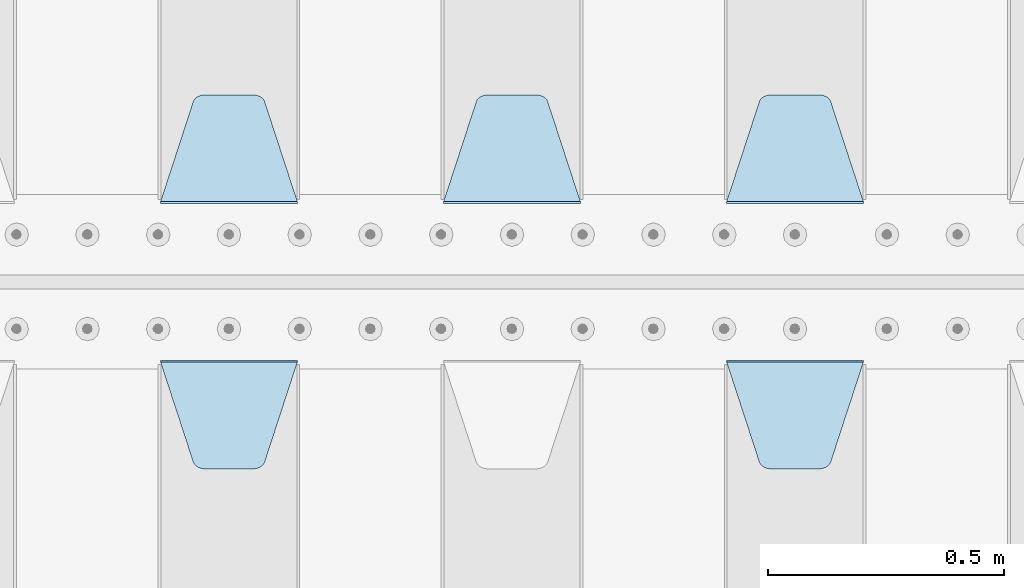
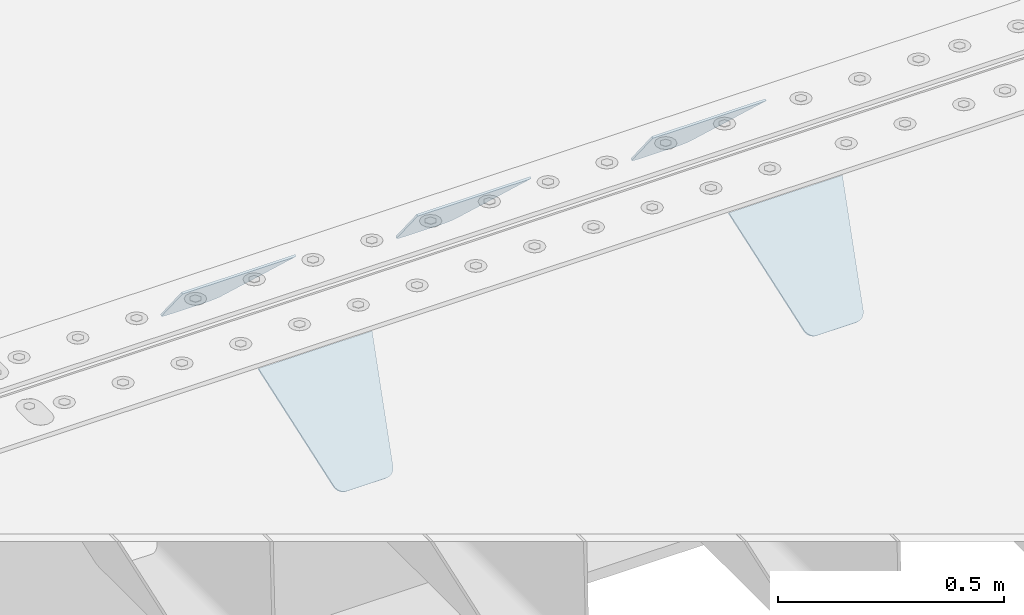
# One storey, part 211 of 247: 5 plates.
"""IFC2X3 building model written with IfcOpenShell, lengths in millimetres."""

from ifc_helpers import new_model, si_unit, frame, origin_with_axes, place, context, subcontext, project, spatial, faceted_brep, material, type_object, element, save


model = new_model("IFC2X3")

# Units and contexts
model_context = context("Model", 3, precision=1e-05, world=origin_with_axes())
body_context = subcontext(model_context, "Body", "Model", "MODEL_VIEW")
ifc_project = project(units=[si_unit("LENGTHUNIT", "METRE", prefix="MILLI"), si_unit("AREAUNIT", "SQUARE_METRE"), si_unit("VOLUMEUNIT", "CUBIC_METRE"), si_unit("MASSUNIT", "GRAM", prefix="KILO"), si_unit("TIMEUNIT", "SECOND"), si_unit("PLANEANGLEUNIT", "RADIAN"), si_unit("SOLIDANGLEUNIT", "STERADIAN"), si_unit("THERMODYNAMICTEMPERATUREUNIT", "DEGREE_CELSIUS"), si_unit("LUMINOUSINTENSITYUNIT", "LUMEN")], contexts=[model_context])

# Site, building, storey
site_placement = place(None, origin_with_axes())
site = spatial("IfcSite", under=ifc_project, at=site_placement, CompositionType="ELEMENT")
building_placement = place(site_placement, origin_with_axes())
building = spatial("IfcBuilding", under=site, at=building_placement, Name="Standard", CompositionType="ELEMENT")
storey_placement = place(building_placement, origin_with_axes())
storey = spatial("IfcBuildingStorey", under=building, at=storey_placement, Name="Undefined", CompositionType="ELEMENT", Elevation=0.0)

# Plates
ifc_material = material(Name="STEEL/S355N")
plate_type = type_object("IfcPlateType", PredefinedType="NOTDEFINED")
plate_1_placement = place(storey_placement, frame((14645.0, 6168.23223304704, -1.76776695296758), z_axis=(0.0, 0.707106781186548, -0.707106781186547), x_axis=(-1.0, 0.0, 0.0)))
element("IfcPlate", 1, at=plate_1_placement, inside=storey, type_object=plate_type, material=ifc_material, context=body_context, shape_type="Brep", body=[
    faceted_brep([(0.0, -2.49999999999909, 0.0), (69.345504679477, -2.5, 300.17173142483), (69.345504679477, 2.50000000000091, 300.171731424831), (0.0, 2.5, -9.09494701772928e-13), (70.9274061199576, -2.5, 304.897442415399), (70.9274061199576, 2.50000000000091, 304.8974424154), (73.3818627772307, -2.49999999999909, 309.234538108527), (73.3818627772307, 2.5, 309.234538108526), (76.6187032999551, -2.5, 313.023683126102), (76.6187032999551, 2.50000000000091, 313.023683126102), (80.5190132704993, -2.49999999999909, 316.125672595371), (80.5190132704993, 2.50000000000091, 316.125672595372), (84.9395038596849, -2.49999999999909, 318.426546230476), (84.9395038596849, 2.5, 318.426546230475), (89.7177759439219, -2.5, 319.841774983274), (89.7177759439219, 2.50000000000091, 319.841774983275), (94.678286292652, -2.5, 320.319366455077), (94.678286292652, 2.50000000000091, 320.319366455077), (195.321713707348, -2.5, 320.319366455077), (195.321713707348, 2.50000000000091, 320.319366455077), (200.282224056078, -2.5, 319.841774983274), (200.282224056078, 2.50000000000091, 319.841774983275), (205.060496140315, -2.5, 318.426546230475), (205.060496140315, 2.5, 318.426546230474), (209.480986729501, -2.49999999999818, 316.12567259537), (209.480986729501, 2.50000000000091, 316.12567259537), (213.381296700045, -2.5, 313.023683126101), (213.381296700045, 2.50000000000091, 313.023683126101), (216.618137222769, -2.5, 309.234538108525), (216.618137222769, 2.5, 309.234538108525), (219.072593880042, -2.49999999999909, 304.897442415398), (219.072593880042, 2.5, 304.897442415398), (220.654495320523, -2.5, 300.17173142483), (220.654495320523, 2.50000000000091, 300.171731424831), (290.0, -2.49999999999909, 0.0), (290.0, 2.5, -9.09494701772928e-13)], [[[0, 1, 2, 3]], [[1, 4, 5, 2]], [[4, 6, 7, 5]], [[6, 8, 9, 7]], [[8, 10, 11, 9]], [[10, 12, 13, 11]], [[12, 14, 15, 13]], [[14, 16, 17, 15]], [[16, 18, 19, 17]], [[18, 20, 21, 19]], [[20, 22, 23, 21]], [[22, 24, 25, 23]], [[24, 26, 27, 25]], [[26, 28, 29, 27]], [[28, 30, 31, 29]], [[30, 32, 33, 31]], [[32, 34, 35, 33]], [[34, 0, 3, 35]], [[5, 7, 9, 11, 13, 15, 17, 19, 21, 23, 25, 27, 29, 31, 33, 35, 3, 2]], [[34, 32, 30, 28, 26, 24, 22, 20, 18, 16, 14, 12, 10, 8, 6, 4, 1, 0]]]),
])
plate_2_placement = place(storey_placement, frame((14355.0, 5831.76776695594, -1.767766952965), z_axis=(0.0, -0.707106781186548, -0.707106781186547), x_axis=(1.0, 0.0, 0.0)))
element("IfcPlate", 2, at=plate_2_placement, inside=storey, type_object=plate_type, material=ifc_material, context=body_context, shape_type="Brep", body=[
    faceted_brep([(0.0, -2.49999999999909, 0.0), (69.345504679477, -2.5, 300.17173142483), (69.345504679477, 2.50000000000091, 300.171731424831), (0.0, 2.5, -9.09494701772928e-13), (70.9274061199576, -2.5, 304.897442415399), (70.9274061199576, 2.50000000000091, 304.8974424154), (73.3818627772307, -2.49999999999909, 309.234538108527), (73.3818627772307, 2.5, 309.234538108526), (76.6187032999551, -2.5, 313.023683126102), (76.6187032999551, 2.50000000000091, 313.023683126102), (80.5190132704993, -2.49999999999909, 316.125672595371), (80.5190132704993, 2.50000000000091, 316.125672595372), (84.9395038596849, -2.49999999999909, 318.426546230476), (84.9395038596849, 2.5, 318.426546230475), (89.7177759439219, -2.5, 319.841774983274), (89.7177759439219, 2.50000000000091, 319.841774983275), (94.678286292652, -2.5, 320.319366455077), (94.678286292652, 2.50000000000091, 320.319366455077), (195.321713707348, -2.5, 320.319366455077), (195.321713707348, 2.50000000000091, 320.319366455077), (200.282224056078, -2.5, 319.841774983274), (200.282224056078, 2.50000000000091, 319.841774983275), (205.060496140315, -2.5, 318.426546230475), (205.060496140315, 2.5, 318.426546230474), (209.480986729501, -2.49999999999818, 316.12567259537), (209.480986729501, 2.50000000000091, 316.12567259537), (213.381296700045, -2.5, 313.023683126101), (213.381296700045, 2.50000000000091, 313.023683126101), (216.618137222769, -2.5, 309.234538108525), (216.618137222769, 2.5, 309.234538108525), (219.072593880042, -2.49999999999909, 304.897442415398), (219.072593880042, 2.5, 304.897442415398), (220.654495320523, -2.5, 300.17173142483), (220.654495320523, 2.50000000000091, 300.171731424831), (290.0, -2.49999999999909, 0.0), (290.0, 2.5, -9.09494701772928e-13)], [[[0, 1, 2, 3]], [[1, 4, 5, 2]], [[4, 6, 7, 5]], [[6, 8, 9, 7]], [[8, 10, 11, 9]], [[10, 12, 13, 11]], [[12, 14, 15, 13]], [[14, 16, 17, 15]], [[16, 18, 19, 17]], [[18, 20, 21, 19]], [[20, 22, 23, 21]], [[22, 24, 25, 23]], [[24, 26, 27, 25]], [[26, 28, 29, 27]], [[28, 30, 31, 29]], [[30, 32, 33, 31]], [[32, 34, 35, 33]], [[34, 0, 3, 35]], [[5, 7, 9, 11, 13, 15, 17, 19, 21, 23, 25, 27, 29, 31, 33, 35, 3, 2]], [[34, 32, 30, 28, 26, 24, 22, 20, 18, 16, 14, 12, 10, 8, 6, 4, 1, 0]]]),
])
plate_3_placement = place(storey_placement, frame((13155.0, 5831.76776695594, -1.767766952965), z_axis=(0.0, -0.707106781186548, -0.707106781186547), x_axis=(1.0, 0.0, 0.0)))
element("IfcPlate", 3, at=plate_3_placement, inside=storey, type_object=plate_type, material=ifc_material, context=body_context, shape_type="Brep", body=[
    faceted_brep([(0.0, -2.49999999999909, 0.0), (69.345504679477, -2.5, 300.17173142483), (69.345504679477, 2.50000000000091, 300.171731424831), (0.0, 2.5, -9.09494701772928e-13), (70.9274061199576, -2.5, 304.897442415399), (70.9274061199576, 2.50000000000091, 304.8974424154), (73.3818627772307, -2.49999999999909, 309.234538108527), (73.3818627772307, 2.5, 309.234538108526), (76.6187032999551, -2.5, 313.023683126102), (76.6187032999551, 2.50000000000091, 313.023683126102), (80.5190132704993, -2.49999999999909, 316.125672595371), (80.5190132704993, 2.50000000000091, 316.125672595372), (84.9395038596849, -2.49999999999909, 318.426546230476), (84.9395038596849, 2.5, 318.426546230475), (89.7177759439219, -2.5, 319.841774983274), (89.7177759439219, 2.50000000000091, 319.841774983275), (94.678286292652, -2.5, 320.319366455077), (94.678286292652, 2.50000000000091, 320.319366455077), (195.321713707348, -2.5, 320.319366455077), (195.321713707348, 2.50000000000091, 320.319366455077), (200.282224056078, -2.5, 319.841774983274), (200.282224056078, 2.50000000000091, 319.841774983275), (205.060496140315, -2.5, 318.426546230475), (205.060496140315, 2.5, 318.426546230474), (209.480986729501, -2.49999999999818, 316.12567259537), (209.480986729501, 2.50000000000091, 316.12567259537), (213.381296700045, -2.5, 313.023683126101), (213.381296700045, 2.50000000000091, 313.023683126101), (216.618137222769, -2.5, 309.234538108525), (216.618137222769, 2.5, 309.234538108525), (219.072593880042, -2.49999999999909, 304.897442415398), (219.072593880042, 2.5, 304.897442415398), (220.654495320523, -2.5, 300.17173142483), (220.654495320523, 2.50000000000091, 300.171731424831), (290.0, -2.49999999999909, 0.0), (290.0, 2.5, -9.09494701772928e-13)], [[[0, 1, 2, 3]], [[1, 4, 5, 2]], [[4, 6, 7, 5]], [[6, 8, 9, 7]], [[8, 10, 11, 9]], [[10, 12, 13, 11]], [[12, 14, 15, 13]], [[14, 16, 17, 15]], [[16, 18, 19, 17]], [[18, 20, 21, 19]], [[20, 22, 23, 21]], [[22, 24, 25, 23]], [[24, 26, 27, 25]], [[26, 28, 29, 27]], [[28, 30, 31, 29]], [[30, 32, 33, 31]], [[32, 34, 35, 33]], [[34, 0, 3, 35]], [[5, 7, 9, 11, 13, 15, 17, 19, 21, 23, 25, 27, 29, 31, 33, 35, 3, 2]], [[34, 32, 30, 28, 26, 24, 22, 20, 18, 16, 14, 12, 10, 8, 6, 4, 1, 0]]]),
])
plate_4_placement = place(storey_placement, frame((14045.0, 6168.23223304704, -1.76776695296758), z_axis=(0.0, 0.707106781186548, -0.707106781186547), x_axis=(-1.0, 0.0, 0.0)))
element("IfcPlate", 4, at=plate_4_placement, inside=storey, type_object=plate_type, material=ifc_material, context=body_context, shape_type="Brep", body=[
    faceted_brep([(0.0, -2.49999999999909, 0.0), (69.345504679477, -2.5, 300.17173142483), (69.345504679477, 2.50000000000091, 300.171731424831), (0.0, 2.5, -9.09494701772928e-13), (70.9274061199576, -2.5, 304.897442415399), (70.9274061199576, 2.50000000000091, 304.8974424154), (73.3818627772307, -2.49999999999909, 309.234538108527), (73.3818627772307, 2.5, 309.234538108526), (76.6187032999551, -2.5, 313.023683126102), (76.6187032999551, 2.50000000000091, 313.023683126102), (80.5190132704993, -2.49999999999909, 316.125672595371), (80.5190132704993, 2.50000000000091, 316.125672595372), (84.9395038596849, -2.49999999999909, 318.426546230476), (84.9395038596849, 2.5, 318.426546230475), (89.7177759439219, -2.5, 319.841774983274), (89.7177759439219, 2.50000000000091, 319.841774983275), (94.678286292652, -2.5, 320.319366455077), (94.678286292652, 2.50000000000091, 320.319366455077), (195.321713707348, -2.5, 320.319366455077), (195.321713707348, 2.50000000000091, 320.319366455077), (200.282224056078, -2.5, 319.841774983274), (200.282224056078, 2.50000000000091, 319.841774983275), (205.060496140315, -2.5, 318.426546230475), (205.060496140315, 2.5, 318.426546230474), (209.480986729501, -2.49999999999818, 316.12567259537), (209.480986729501, 2.50000000000091, 316.12567259537), (213.381296700045, -2.5, 313.023683126101), (213.381296700045, 2.50000000000091, 313.023683126101), (216.618137222769, -2.5, 309.234538108525), (216.618137222769, 2.5, 309.234538108525), (219.072593880042, -2.49999999999909, 304.897442415398), (219.072593880042, 2.5, 304.897442415398), (220.654495320523, -2.5, 300.17173142483), (220.654495320523, 2.50000000000091, 300.171731424831), (290.0, -2.49999999999909, 0.0), (290.0, 2.5, -9.09494701772928e-13)], [[[0, 1, 2, 3]], [[1, 4, 5, 2]], [[4, 6, 7, 5]], [[6, 8, 9, 7]], [[8, 10, 11, 9]], [[10, 12, 13, 11]], [[12, 14, 15, 13]], [[14, 16, 17, 15]], [[16, 18, 19, 17]], [[18, 20, 21, 19]], [[20, 22, 23, 21]], [[22, 24, 25, 23]], [[24, 26, 27, 25]], [[26, 28, 29, 27]], [[28, 30, 31, 29]], [[30, 32, 33, 31]], [[32, 34, 35, 33]], [[34, 0, 3, 35]], [[5, 7, 9, 11, 13, 15, 17, 19, 21, 23, 25, 27, 29, 31, 33, 35, 3, 2]], [[34, 32, 30, 28, 26, 24, 22, 20, 18, 16, 14, 12, 10, 8, 6, 4, 1, 0]]]),
])
plate_5_placement = place(storey_placement, frame((13445.0, 6168.23223304704, -1.76776695296758), z_axis=(0.0, 0.707106781186548, -0.707106781186547), x_axis=(-1.0, 0.0, 0.0)))
element("IfcPlate", 5, at=plate_5_placement, inside=storey, type_object=plate_type, material=ifc_material, context=body_context, shape_type="Brep", body=[
    faceted_brep([(0.0, -2.49999999999909, 0.0), (69.345504679477, -2.5, 300.17173142483), (69.345504679477, 2.50000000000091, 300.171731424831), (0.0, 2.5, -9.09494701772928e-13), (70.9274061199576, -2.5, 304.897442415399), (70.9274061199576, 2.50000000000091, 304.8974424154), (73.3818627772307, -2.49999999999909, 309.234538108527), (73.3818627772307, 2.5, 309.234538108526), (76.6187032999551, -2.5, 313.023683126102), (76.6187032999551, 2.50000000000091, 313.023683126102), (80.5190132704993, -2.49999999999909, 316.125672595371), (80.5190132704993, 2.50000000000091, 316.125672595372), (84.9395038596849, -2.49999999999909, 318.426546230476), (84.9395038596849, 2.5, 318.426546230475), (89.7177759439219, -2.5, 319.841774983274), (89.7177759439219, 2.50000000000091, 319.841774983275), (94.678286292652, -2.5, 320.319366455077), (94.678286292652, 2.50000000000091, 320.319366455077), (195.321713707348, -2.5, 320.319366455077), (195.321713707348, 2.50000000000091, 320.319366455077), (200.282224056078, -2.5, 319.841774983274), (200.282224056078, 2.50000000000091, 319.841774983275), (205.060496140315, -2.5, 318.426546230475), (205.060496140315, 2.5, 318.426546230474), (209.480986729501, -2.49999999999818, 316.12567259537), (209.480986729501, 2.50000000000091, 316.12567259537), (213.381296700045, -2.5, 313.023683126101), (213.381296700045, 2.50000000000091, 313.023683126101), (216.618137222769, -2.5, 309.234538108525), (216.618137222769, 2.5, 309.234538108525), (219.072593880042, -2.49999999999909, 304.897442415398), (219.072593880042, 2.5, 304.897442415398), (220.654495320523, -2.5, 300.17173142483), (220.654495320523, 2.50000000000091, 300.171731424831), (290.0, -2.49999999999909, 0.0), (290.0, 2.5, -9.09494701772928e-13)], [[[0, 1, 2, 3]], [[1, 4, 5, 2]], [[4, 6, 7, 5]], [[6, 8, 9, 7]], [[8, 10, 11, 9]], [[10, 12, 13, 11]], [[12, 14, 15, 13]], [[14, 16, 17, 15]], [[16, 18, 19, 17]], [[18, 20, 21, 19]], [[20, 22, 23, 21]], [[22, 24, 25, 23]], [[24, 26, 27, 25]], [[26, 28, 29, 27]], [[28, 30, 31, 29]], [[30, 32, 33, 31]], [[32, 34, 35, 33]], [[34, 0, 3, 35]], [[5, 7, 9, 11, 13, 15, 17, 19, 21, 23, 25, 27, 29, 31, 33, 35, 3, 2]], [[34, 32, 30, 28, 26, 24, 22, 20, 18, 16, 14, 12, 10, 8, 6, 4, 1, 0]]]),
])

save(model, "model.ifc")
